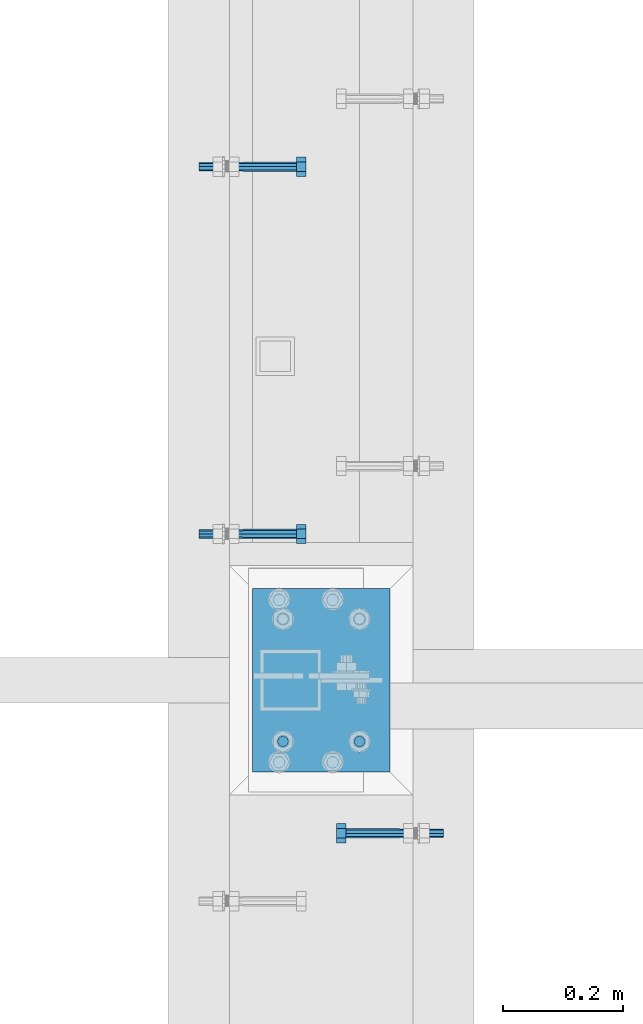
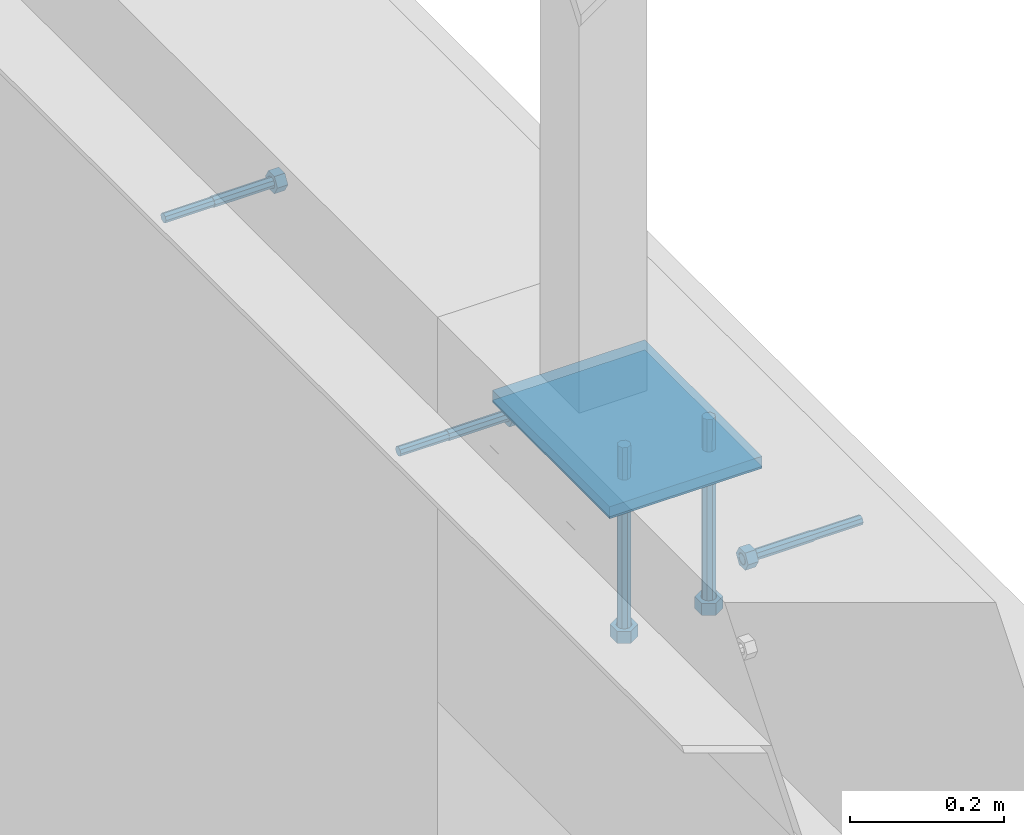
# One storey, part 390 of 975: 7 beams.
"""IFC2X3 building model written with IfcOpenShell, lengths in millimetres."""

from ifc_helpers import new_model, si_unit, frame, origin_with_axes, place, context, subcontext, project, spatial, faceted_brep, material, type_object, element, save


model = new_model("IFC2X3")

# Units and contexts
model_context = context("Model", 3, precision=1e-05, world=origin_with_axes())
body_context = subcontext(model_context, "Body", "Model", "MODEL_VIEW")
ifc_project = project(units=[si_unit("LENGTHUNIT", "METRE", prefix="MILLI"), si_unit("AREAUNIT", "SQUARE_METRE"), si_unit("VOLUMEUNIT", "CUBIC_METRE"), si_unit("MASSUNIT", "GRAM", prefix="KILO"), si_unit("TIMEUNIT", "SECOND"), si_unit("PLANEANGLEUNIT", "RADIAN"), si_unit("SOLIDANGLEUNIT", "STERADIAN"), si_unit("THERMODYNAMICTEMPERATUREUNIT", "DEGREE_CELSIUS"), si_unit("LUMINOUSINTENSITYUNIT", "LUMEN")], contexts=[model_context])

# Site, building, storey
site_placement = place(None, origin_with_axes())
site = spatial("IfcSite", under=ifc_project, at=site_placement, CompositionType="ELEMENT")
building_placement = place(site_placement, origin_with_axes())
building = spatial("IfcBuilding", under=site, at=building_placement, Name="Undefined", CompositionType="ELEMENT")
storey_placement = place(building_placement, origin_with_axes())
storey = spatial("IfcBuildingStorey", under=building, at=storey_placement, Name="Undefined", CompositionType="ELEMENT", Elevation=0.0)

# Beams
ifc_material_1 = material(Name="STEEL/F1554-36")
beam_type_1 = type_object("IfcBeamType", PredefinedType="NOTDEFINED")
beam_1_placement = place(storey_placement, frame((2038.34998493445, 7967.66249985328, 3835.4), z_axis=(0.0, 0.0, -1.0), x_axis=(1.0, 0.0, 0.0)))
element("IfcBeam", 1, at=beam_1_placement, inside=storey, type_object=beam_type_1, material=ifc_material_1, Name="HEADED_ANCHOR_BOLT", context=body_context, shape_type="Brep", body=[
    faceted_brep([(88.9000000184824, 7.94000001861696, -13.7499999799138), (88.8999999527368, 15.8800000758411, 2.00943759409711e-08), (104.774999952569, 15.8800001213949, 6.97191353538074e-08), (104.775000018315, 7.94000006417082, -13.7499999302891), (88.900000064019, -7.94000009583215, -13.7499999799147), (104.775000063852, -7.9400000502792, -13.74999993029), (88.9000000438027, -15.880000153059, 2.00925569515675e-08), (104.775000043643, -15.8800001075042, 6.9716406869702e-08), (88.8999999780608, -7.94000009583488, 13.7500000200998), (104.774999977893, -7.94000005028101, 13.7500000697237), (88.8999999325279, 7.94000001861514, 13.7500000201007), (104.774999932361, 7.940000064169, 13.7500000697246), (88.9000000119959, 3.78780480527439, -7.86545778426807), (88.8999999957159, 6.82538844544797, -5.4430656647246), (88.8999999799416, 8.51112018845743, -1.94260763148395), (88.8999999677944, 8.51112018845652, 1.94260767167179), (88.8999999616899, 6.82538844544615, 5.44306570491244), (88.8999999628249, 3.78780480527257, 7.86545782445592), (88.8999999709849, -3.86089595849626e-08, 8.72999956233434), (88.8999999845473, -3.7878048824914, 7.8654578244541), (88.9000000008309, -6.82538852266407, 5.44306570491153), (88.9000000166052, -8.51112026567444, 1.94260767166998), (88.9000000287488, -8.51112026567353, -1.94260763148577), (88.9000000348606, -6.82538852266407, -5.44306566472642), (88.9000000337182, -3.78780488248958, -7.86545778426898), (88.9000000255583, -3.86080500902608e-08, -8.72999952214832), (104.775000025395, 6.94581103743985e-09, -8.72999947252447), (104.775000011829, 3.78780485082825, -7.86545773464422), (104.774999995549, 6.82538849100092, -5.44306561510075), (104.774999979774, 8.51112023401038, -1.9426075818601), (104.774999967627, 8.51112023401038, 1.94260772129564), (104.774999961523, 6.82538849100092, 5.44306575453629), (104.774999962658, 3.78780485082643, 7.86545787407977), (104.774999970818, 6.94399204803631e-09, 8.7299996119591), (104.77499998438, -3.78780483693754, 7.86545787407886), (104.775000000664, -6.82538847711112, 5.44306575453538), (104.775000016438, -8.51112022012057, 1.94260772129473), (104.775000028581, -8.51112022012057, -1.94260758186101), (104.775000034693, -6.82538847711021, -5.44306561510166), (104.775000033551, -3.78780483693663, -7.86545773464422), (-2.99107341561466e-07, -5.61266007567065, 5.61266007566792), (-4.22995071858168e-07, -7.93750000000728, 0.0), (104.774999998088, -7.93749999999, -4.45652403868735e-11), (104.774999998088, -5.61266007565791, 5.61266007562426), (-1.09139364212751e-11, 1.81898940354586e-12, 7.9375), (104.774999998095, 1.18234311230481e-11, 7.93749999995816), (2.99089151667431e-07, 5.61266007567428, 5.61266007566792), (104.774999998102, 5.61266007568065, 5.61266007562517), (4.22980519942939e-07, 7.93750000001091, 0.0), (104.77499999811, 7.93750000001364, -4.36557456851006e-11), (2.99089151667431e-07, 5.61266007567428, -5.61266007566792), (104.774999998102, 5.61266007568156, -5.61266007571339), (-1.09139364212751e-11, 1.81898940354586e-12, -7.9375), (104.774999998099, 1.2732925824821e-11, -7.93750000004547), (-73.0249999592124, 5.05157065939329, -5.0515715445581), (-73.0249999269472, -1.85405951924622e-07, -7.14400069976364), (-73.0249999328516, -5.0515710302052, -5.05157154455992), (-73.0249999734697, -7.14400018541073, -6.9975976657588e-07), (-73.0250000250016, -5.05157103020611, 5.05157014504039), (-73.0250000572705, -1.85406861419324e-07, 7.1439993002441), (-73.0250000513661, 5.05157065939238, 5.05157014503948), (-73.025000010748, 7.14399981459792, -6.99758857081179e-07), (0.00625003290042514, 5.05157085007795, -5.05157087849238), (0.00625006516929716, 5.27870724909008e-09, -7.1440000336961), (0.00625005926485755, -5.05157083952145, -5.05157087849329), (0.00625001864682417, -7.14399999472516, -3.36940502165817e-08), (0.00624996711121639, -5.05157083952145, 5.05157081110519), (0.00624993484598235, 5.2777977543883e-09, 7.14399996631164), (0.00624994074678398, 5.05157085007704, 5.05157081110701), (0.00624998136845534, 7.14400000528167, -3.36922312271781e-08), (-2.99107341561466e-07, -5.61266007567065, -5.61266007566792), (104.774999998092, -5.612660075657, -5.6126600757143)], [[[0, 1, 2, 3]], [[4, 0, 3, 5]], [[6, 4, 5, 7]], [[8, 6, 7, 9]], [[10, 8, 9, 11]], [[0, 4, 6, 8, 10, 1], [12, 13, 14, 15, 16, 17, 18, 19, 20, 21, 22, 23, 24, 25]], [[12, 25, 26, 27]], [[13, 12, 27, 28]], [[14, 13, 28, 29]], [[15, 14, 29, 30]], [[16, 15, 30, 31]], [[17, 16, 31, 32]], [[18, 17, 32, 33]], [[19, 18, 33, 34]], [[20, 19, 34, 35]], [[21, 20, 35, 36]], [[22, 21, 36, 37]], [[23, 22, 37, 38]], [[24, 23, 38, 39]], [[25, 24, 39, 26]], [[9, 7, 5, 3, 2, 11], [38, 37, 36, 35, 34, 33, 32, 31, 30, 29, 28, 27, 26, 39]], [[1, 10, 11, 2]], [[40, 41, 42, 43]], [[44, 40, 43, 45]], [[46, 44, 45, 47]], [[48, 46, 47, 49]], [[50, 48, 49, 51]], [[52, 50, 51, 53]], [[54, 55, 56, 57, 58, 59, 60, 61]], [[55, 54, 62, 63]], [[56, 55, 63, 64]], [[57, 56, 64, 65]], [[58, 57, 65, 66]], [[59, 58, 66, 67]], [[60, 59, 67, 68]], [[61, 60, 68, 69]], [[54, 61, 69, 62]], [[40, 44, 46, 48, 50, 52, 70, 41], [68, 67, 66, 65, 64, 63, 62, 69]], [[41, 70, 71, 42]], [[53, 51, 49, 47, 45, 43, 42, 71]], [[70, 52, 53, 71]]]),
])
beam_2_placement = place(storey_placement, frame((2038.34998066725, 7358.06240219702, 3835.4), z_axis=(0.0, 0.0, -1.0), x_axis=(1.0, 0.0, 0.0)))
element("IfcBeam", 2, at=beam_2_placement, inside=storey, type_object=beam_type_1, material=ifc_material_1, Name="HEADED_ANCHOR_BOLT", context=body_context, shape_type="Brep", body=[
    faceted_brep([(88.9000000184824, 7.94000001861696, -13.7499999799138), (88.8999999527368, 15.8800000758411, 2.00943759409711e-08), (104.774999952569, 15.8800001213949, 6.97191353538074e-08), (104.775000018315, 7.94000006417082, -13.7499999302891), (88.900000064019, -7.94000009583215, -13.7499999799147), (104.775000063852, -7.9400000502792, -13.74999993029), (88.9000000438027, -15.880000153059, 2.00925569515675e-08), (104.775000043643, -15.8800001075042, 6.9716406869702e-08), (88.8999999780608, -7.94000009583488, 13.7500000200998), (104.774999977893, -7.94000005028101, 13.7500000697237), (88.8999999325279, 7.94000001861514, 13.7500000201007), (104.774999932361, 7.940000064169, 13.7500000697246), (88.9000000119959, 3.78780480527439, -7.86545778426807), (88.8999999957159, 6.82538844544797, -5.4430656647246), (88.8999999799416, 8.51112018845743, -1.94260763148395), (88.8999999677944, 8.51112018845652, 1.94260767167179), (88.8999999616899, 6.82538844544615, 5.44306570491244), (88.8999999628249, 3.78780480527257, 7.86545782445592), (88.8999999709849, -3.86089595849626e-08, 8.72999956233434), (88.8999999845473, -3.7878048824914, 7.8654578244541), (88.9000000008309, -6.82538852266407, 5.44306570491153), (88.9000000166052, -8.51112026567444, 1.94260767166998), (88.9000000287488, -8.51112026567353, -1.94260763148577), (88.9000000348606, -6.82538852266407, -5.44306566472642), (88.9000000337182, -3.78780488248958, -7.86545778426898), (88.9000000255583, -3.86080500902608e-08, -8.72999952214832), (104.775000025395, 6.94581103743985e-09, -8.72999947252447), (104.775000011829, 3.78780485082825, -7.86545773464422), (104.774999995549, 6.82538849100092, -5.44306561510075), (104.774999979774, 8.51112023401038, -1.9426075818601), (104.774999967627, 8.51112023401038, 1.94260772129564), (104.774999961523, 6.82538849100092, 5.44306575453629), (104.774999962658, 3.78780485082643, 7.86545787407977), (104.774999970818, 6.94399204803631e-09, 8.7299996119591), (104.77499998438, -3.78780483693754, 7.86545787407886), (104.775000000664, -6.82538847711112, 5.44306575453538), (104.775000016438, -8.51112022012057, 1.94260772129473), (104.775000028581, -8.51112022012057, -1.94260758186101), (104.775000034693, -6.82538847711021, -5.44306561510166), (104.775000033551, -3.78780483693663, -7.86545773464422), (-2.99107341561466e-07, -5.61266007567065, 5.61266007566792), (-4.22995071858168e-07, -7.93750000000728, 0.0), (104.774999998088, -7.93749999999, -4.45652403868735e-11), (104.774999998088, -5.61266007565791, 5.61266007562426), (-1.09139364212751e-11, 1.81898940354586e-12, 7.9375), (104.774999998095, 1.18234311230481e-11, 7.93749999995816), (2.99089151667431e-07, 5.61266007567428, 5.61266007566792), (104.774999998102, 5.61266007568065, 5.61266007562517), (4.22980519942939e-07, 7.93750000001091, 0.0), (104.77499999811, 7.93750000001364, -4.36557456851006e-11), (2.99089151667431e-07, 5.61266007567428, -5.61266007566792), (104.774999998102, 5.61266007568156, -5.61266007571339), (-1.09139364212751e-11, 1.81898940354586e-12, -7.9375), (104.774999998099, 1.2732925824821e-11, -7.93750000004547), (-73.0249999592124, 5.05157065939329, -5.0515715445581), (-73.0249999269472, -1.85405951924622e-07, -7.14400069976364), (-73.0249999328516, -5.0515710302052, -5.05157154455992), (-73.0249999734697, -7.14400018541073, -6.9975976657588e-07), (-73.0250000250016, -5.05157103020611, 5.05157014504039), (-73.0250000572705, -1.85406861419324e-07, 7.1439993002441), (-73.0250000513661, 5.05157065939238, 5.05157014503948), (-73.025000010748, 7.14399981459792, -6.99758857081179e-07), (0.00625003290042514, 5.05157085007795, -5.05157087849238), (0.00625006516929716, 5.27870724909008e-09, -7.1440000336961), (0.00625005926485755, -5.05157083952145, -5.05157087849329), (0.00625001864682417, -7.14399999472516, -3.36940502165817e-08), (0.00624996711121639, -5.05157083952145, 5.05157081110519), (0.00624993484598235, 5.2777977543883e-09, 7.14399996631164), (0.00624994074678398, 5.05157085007704, 5.05157081110701), (0.00624998136845534, 7.14400000528167, -3.36922312271781e-08), (-2.99107341561466e-07, -5.61266007567065, -5.61266007566792), (104.774999998092, -5.612660075657, -5.6126600757143)], [[[0, 1, 2, 3]], [[4, 0, 3, 5]], [[6, 4, 5, 7]], [[8, 6, 7, 9]], [[10, 8, 9, 11]], [[0, 4, 6, 8, 10, 1], [12, 13, 14, 15, 16, 17, 18, 19, 20, 21, 22, 23, 24, 25]], [[12, 25, 26, 27]], [[13, 12, 27, 28]], [[14, 13, 28, 29]], [[15, 14, 29, 30]], [[16, 15, 30, 31]], [[17, 16, 31, 32]], [[18, 17, 32, 33]], [[19, 18, 33, 34]], [[20, 19, 34, 35]], [[21, 20, 35, 36]], [[22, 21, 36, 37]], [[23, 22, 37, 38]], [[24, 23, 38, 39]], [[25, 24, 39, 26]], [[9, 7, 5, 3, 2, 11], [38, 37, 36, 35, 34, 33, 32, 31, 30, 29, 28, 27, 26, 39]], [[1, 10, 11, 2]], [[40, 41, 42, 43]], [[44, 40, 43, 45]], [[46, 44, 45, 47]], [[48, 46, 47, 49]], [[50, 48, 49, 51]], [[52, 50, 51, 53]], [[54, 55, 56, 57, 58, 59, 60, 61]], [[55, 54, 62, 63]], [[56, 55, 63, 64]], [[57, 56, 64, 65]], [[58, 57, 65, 66]], [[59, 58, 66, 67]], [[60, 59, 67, 68]], [[61, 60, 68, 69]], [[54, 61, 69, 62]], [[40, 44, 46, 48, 50, 52, 70, 41], [68, 67, 66, 65, 64, 63, 62, 69]], [[41, 70, 71, 42]], [[53, 51, 49, 47, 45, 43, 42, 71]], [[70, 52, 53, 71]]]),
])
beam_3_placement = place(storey_placement, frame((2298.70006496676, 6861.17497611239, 3886.2), z_axis=(0.0, 0.0, 1.0), x_axis=(-0.999999999999998, 6.90000001668524e-08, 0.0)))
element("IfcBeam", 3, at=beam_3_placement, inside=storey, type_object=beam_type_1, material=ifc_material_1, Name="HEADED_ANCHOR_BOLT", context=body_context, shape_type="Brep", body=[
    faceted_brep([(88.9000000184824, 7.94000001861696, -13.7499999799138), (88.8999999527368, 15.8800000758411, 2.00943759409711e-08), (104.774999952569, 15.8800001213949, 6.97191353538074e-08), (104.775000018315, 7.94000006417082, -13.7499999302891), (88.900000064019, -7.94000009583215, -13.7499999799147), (104.775000063852, -7.9400000502792, -13.74999993029), (88.9000000438027, -15.880000153059, 2.00925569515675e-08), (104.775000043643, -15.8800001075042, 6.9716406869702e-08), (88.8999999780608, -7.94000009583488, 13.7500000200998), (104.774999977893, -7.94000005028101, 13.7500000697237), (88.8999999325279, 7.94000001861514, 13.7500000201007), (104.774999932361, 7.940000064169, 13.7500000697246), (88.9000000119959, 3.78780480527439, -7.86545778426807), (88.8999999957159, 6.82538844544797, -5.4430656647246), (88.8999999799416, 8.51112018845743, -1.94260763148395), (88.8999999677944, 8.51112018845652, 1.94260767167179), (88.8999999616899, 6.82538844544615, 5.44306570491244), (88.8999999628249, 3.78780480527257, 7.86545782445592), (88.8999999709849, -3.86089595849626e-08, 8.72999956233434), (88.8999999845473, -3.7878048824914, 7.8654578244541), (88.9000000008309, -6.82538852266407, 5.44306570491153), (88.9000000166052, -8.51112026567444, 1.94260767166998), (88.9000000287488, -8.51112026567353, -1.94260763148577), (88.9000000348606, -6.82538852266407, -5.44306566472642), (88.9000000337182, -3.78780488248958, -7.86545778426898), (88.9000000255583, -3.86080500902608e-08, -8.72999952214832), (104.775000025395, 6.94581103743985e-09, -8.72999947252447), (104.775000011829, 3.78780485082825, -7.86545773464422), (104.774999995549, 6.82538849100092, -5.44306561510075), (104.774999979774, 8.51112023401038, -1.9426075818601), (104.774999967627, 8.51112023401038, 1.94260772129564), (104.774999961523, 6.82538849100092, 5.44306575453629), (104.774999962658, 3.78780485082643, 7.86545787407977), (104.774999970818, 6.94399204803631e-09, 8.7299996119591), (104.77499998438, -3.78780483693754, 7.86545787407886), (104.775000000664, -6.82538847711112, 5.44306575453538), (104.775000016438, -8.51112022012057, 1.94260772129473), (104.775000028581, -8.51112022012057, -1.94260758186101), (104.775000034693, -6.82538847711021, -5.44306561510166), (104.775000033551, -3.78780483693663, -7.86545773464422), (-2.99107341561466e-07, -5.61266007567065, 5.61266007566792), (-4.22995071858168e-07, -7.93750000000728, 0.0), (104.774999998088, -7.93749999999, -4.45652403868735e-11), (104.774999998088, -5.61266007565791, 5.61266007562426), (-1.09139364212751e-11, 1.81898940354586e-12, 7.9375), (104.774999998095, 1.18234311230481e-11, 7.93749999995816), (2.99089151667431e-07, 5.61266007567428, 5.61266007566792), (104.774999998102, 5.61266007568065, 5.61266007562517), (4.22980519942939e-07, 7.93750000001091, 0.0), (104.77499999811, 7.93750000001364, -4.36557456851006e-11), (2.99089151667431e-07, 5.61266007567428, -5.61266007566792), (104.774999998102, 5.61266007568156, -5.61266007571339), (-1.09139364212751e-11, 1.81898940354586e-12, -7.9375), (104.774999998099, 1.2732925824821e-11, -7.93750000004547), (-73.0249999592124, 5.05157065939329, -5.0515715445581), (-73.0249999269472, -1.85405951924622e-07, -7.14400069976364), (-73.0249999328516, -5.0515710302052, -5.05157154455992), (-73.0249999734697, -7.14400018541073, -6.9975976657588e-07), (-73.0250000250016, -5.05157103020611, 5.05157014504039), (-73.0250000572705, -1.85406861419324e-07, 7.1439993002441), (-73.0250000513661, 5.05157065939238, 5.05157014503948), (-73.025000010748, 7.14399981459792, -6.99758857081179e-07), (0.00625003290042514, 5.05157085007795, -5.05157087849238), (0.00625006516929716, 5.27870724909008e-09, -7.1440000336961), (0.00625005926485755, -5.05157083952145, -5.05157087849329), (0.00625001864682417, -7.14399999472516, -3.36940502165817e-08), (0.00624996711121639, -5.05157083952145, 5.05157081110519), (0.00624993484598235, 5.2777977543883e-09, 7.14399996631164), (0.00624994074678398, 5.05157085007704, 5.05157081110701), (0.00624998136845534, 7.14400000528167, -3.36922312271781e-08), (-2.99107341561466e-07, -5.61266007567065, -5.61266007566792), (104.774999998092, -5.612660075657, -5.6126600757143)], [[[0, 1, 2, 3]], [[4, 0, 3, 5]], [[6, 4, 5, 7]], [[8, 6, 7, 9]], [[10, 8, 9, 11]], [[0, 4, 6, 8, 10, 1], [12, 13, 14, 15, 16, 17, 18, 19, 20, 21, 22, 23, 24, 25]], [[12, 25, 26, 27]], [[13, 12, 27, 28]], [[14, 13, 28, 29]], [[15, 14, 29, 30]], [[16, 15, 30, 31]], [[17, 16, 31, 32]], [[18, 17, 32, 33]], [[19, 18, 33, 34]], [[20, 19, 34, 35]], [[21, 20, 35, 36]], [[22, 21, 36, 37]], [[23, 22, 37, 38]], [[24, 23, 38, 39]], [[25, 24, 39, 26]], [[9, 7, 5, 3, 2, 11], [38, 37, 36, 35, 34, 33, 32, 31, 30, 29, 28, 27, 26, 39]], [[1, 10, 11, 2]], [[40, 41, 42, 43]], [[44, 40, 43, 45]], [[46, 44, 45, 47]], [[48, 46, 47, 49]], [[50, 48, 49, 51]], [[52, 50, 51, 53]], [[54, 55, 56, 57, 58, 59, 60, 61]], [[55, 54, 62, 63]], [[56, 55, 63, 64]], [[57, 56, 64, 65]], [[58, 57, 65, 66]], [[59, 58, 66, 67]], [[60, 59, 67, 68]], [[61, 60, 68, 69]], [[54, 61, 69, 62]], [[40, 44, 46, 48, 50, 52, 70, 41], [68, 67, 66, 65, 64, 63, 62, 69]], [[41, 70, 71, 42]], [[53, 51, 49, 47, 45, 43, 42, 71]], [[70, 52, 53, 71]]]),
])
beam_type_2 = type_object("IfcBeamType", PredefinedType="NOTDEFINED")
beam_4_placement = place(storey_placement, frame((2105.025, 7013.57499984381, 3917.95), z_axis=(1.0, 0.0, 0.0), x_axis=(0.0, 0.0, -1.0)))
element("IfcBeam", 4, at=beam_4_placement, inside=storey, type_object=beam_type_2, material=ifc_material_1, Name="HEADED_BOLT", context=body_context, shape_type="Brep", body=[
    faceted_brep([(196.84375, -9.12999965559902, 15.8099993757314), (196.84375, -18.2599997700399, -1.0438852768857e-06), (215.893749999999, -18.2599997700399, -1.0438852768857e-06), (215.893749999999, -9.12999965559902, 15.8099993757314), (196.84375, 9.13000057328281, 15.8099993757314), (215.893749999999, 9.13000057328281, 15.8099993757314), (196.84375, 18.2600006877237, -1.0438852768857e-06), (215.893749999999, 18.2600006877237, -1.0438852768857e-06), (196.84375, 9.13000057328281, -15.810001463502), (215.893749999999, 9.13000057328281, -15.810001463502), (196.84375, -9.12999965559902, -15.810001463502), (215.893749999999, -9.12999965559902, -15.810001463502), (196.84375, -4.47767959644079, 9.2979973979138), (196.84375, -8.06850020163256, 6.43441352102286), (196.84375, -10.0612552973498, 2.29641492663589), (196.84375, -10.0612552973498, -2.29641701440644), (196.84375, -8.06850020163256, -6.43441560879344), (196.84375, -4.47767959644079, -9.29799948568439), (196.84375, 4.58841896033846e-07, -10.3200007387095), (196.84375, 4.47768051412459, -9.29799948568436), (196.84375, 8.06850111931635, -6.43441560879342), (196.84375, 10.0612562150336, -2.29641701440644), (196.84375, 10.0612562150336, 2.29641492663589), (196.84375, 8.06850111931635, 6.43441352102289), (196.84375, 4.47768051412459, 9.29799739791383), (196.84375, 4.58841896033846e-07, 10.3199986509389), (215.893749999999, 4.58841896033846e-07, 10.3199986509389), (215.893749999999, -4.47767959644079, 9.2979973979138), (215.893749999999, -8.06850020163256, 6.43441352102286), (215.893749999999, -10.0612552973498, 2.29641492663589), (215.893749999999, -10.0612552973498, -2.29641701440644), (215.893749999999, -8.06850020163256, -6.43441560879344), (215.893749999999, -4.47767959644079, -9.29799948568439), (215.893749999999, 4.58841896033846e-07, -10.3200007387095), (215.893749999999, 4.47768051412459, -9.29799948568436), (215.893749999999, 8.06850111931635, -6.43441560879342), (215.893749999999, 10.0612562150336, -2.29641701440644), (215.893749999999, 10.0612562150336, 2.29641492663589), (215.893749999999, 8.06850111931635, 6.43441352102289), (215.893749999999, 4.47768051412459, 9.29799739791383), (0.0, -6.73519209080223, 6.73519209080186), (0.0, -9.52499999999964, 0.0), (215.900000000001, -9.52499999999964, 0.0), (215.900000000001, -6.73519209080223, 6.73519209080186), (-9.87109982941227e-13, -1.20792265079217e-13, 9.52499961853027), (215.900000000001, 0.0, 9.52500000000001), (0.0, 6.73519209080223, 6.73519209080186), (215.900000000001, 6.73519209080223, 6.73519209080186), (0.0, 9.52499999999964, 0.0), (215.900000000001, 9.52499999999964, 0.0), (0.0, 6.73519209080223, -6.73519209080186), (215.900000000001, 6.73519209080223, -6.73519209080186), (2.95075507493764e-12, -1.20792265079217e-13, -9.52499961853027), (215.900000000001, 0.0, -9.52500000000001), (-88.9444446471748, -6.3639605718372, 6.39952908988423), (-88.9433906823501, 4.58841896033846e-07, 9.03556784850662), (-88.9444446471748, 6.36396148952099, 6.39952908988423), (-88.9469891433491, 9.0000004588419, 0.0355685678769078), (-88.9495336395235, 6.36396148952099, -6.32839195413041), (-88.9505876043481, 4.58841896033846e-07, -8.9644307127528), (-88.9495336395235, -6.3639605718372, -6.32839195413041), (-88.9469891433491, -8.9999995411581, 0.0355685678769078), (0.0124298302243915, 6.36396148952099, -6.36396152997716), (0.0113758653997138, 4.58841896033846e-07, -9.00000028859955), (0.0124298302243915, -6.3639605718372, -6.36396152997716), (0.0149743263987148, -8.9999995411581, -1.00796984270346e-06), (0.0175188225730381, -6.3639605718372, 6.36395951403748), (0.0185727873977157, 4.58841896033846e-07, 8.99999827265987), (0.0175188225730381, 6.36396148952099, 6.36395951403748), (0.0149743263987148, 9.0000004588419, -1.00796984270346e-06), (0.0, -6.73519209080223, -6.73519209080186), (215.900000000001, -6.73519209080223, -6.73519209080186)], [[[0, 1, 2, 3]], [[4, 0, 3, 5]], [[6, 4, 5, 7]], [[8, 6, 7, 9]], [[10, 8, 9, 11]], [[0, 4, 6, 8, 10, 1], [12, 13, 14, 15, 16, 17, 18, 19, 20, 21, 22, 23, 24, 25]], [[12, 25, 26, 27]], [[13, 12, 27, 28]], [[14, 13, 28, 29]], [[15, 14, 29, 30]], [[16, 15, 30, 31]], [[17, 16, 31, 32]], [[18, 17, 32, 33]], [[19, 18, 33, 34]], [[20, 19, 34, 35]], [[21, 20, 35, 36]], [[22, 21, 36, 37]], [[23, 22, 37, 38]], [[24, 23, 38, 39]], [[25, 24, 39, 26]], [[9, 7, 5, 3, 2, 11], [38, 37, 36, 35, 34, 33, 32, 31, 30, 29, 28, 27, 26, 39]], [[1, 10, 11, 2]], [[40, 41, 42, 43]], [[44, 40, 43, 45]], [[46, 44, 45, 47]], [[48, 46, 47, 49]], [[50, 48, 49, 51]], [[52, 50, 51, 53]], [[54, 55, 56, 57, 58, 59, 60, 61]], [[59, 58, 62, 63]], [[60, 59, 63, 64]], [[61, 60, 64, 65]], [[54, 61, 65, 66]], [[55, 54, 66, 67]], [[56, 55, 67, 68]], [[57, 56, 68, 69]], [[58, 57, 69, 62]], [[40, 44, 46, 48, 50, 52, 70, 41], [68, 67, 66, 65, 64, 63, 62, 69]], [[41, 70, 71, 42]], [[53, 51, 49, 47, 45, 43, 42, 71]], [[70, 52, 53, 71]]]),
])
beam_5_placement = place(storey_placement, frame((2232.0249962741, 7013.57499984381, 3917.95), z_axis=(1.0, 0.0, 0.0), x_axis=(0.0, 0.0, -1.0)))
element("IfcBeam", 5, at=beam_5_placement, inside=storey, type_object=beam_type_2, material=ifc_material_1, Name="HEADED_BOLT", context=body_context, shape_type="Brep", body=[
    faceted_brep([(196.84375, -9.12999965559902, 15.8099993757314), (196.84375, -18.2599997700399, -1.0438852768857e-06), (215.893749999999, -18.2599997700399, -1.0438852768857e-06), (215.893749999999, -9.12999965559902, 15.8099993757314), (196.84375, 9.13000057328281, 15.8099993757314), (215.893749999999, 9.13000057328281, 15.8099993757314), (196.84375, 18.2600006877237, -1.0438852768857e-06), (215.893749999999, 18.2600006877237, -1.0438852768857e-06), (196.84375, 9.13000057328281, -15.810001463502), (215.893749999999, 9.13000057328281, -15.810001463502), (196.84375, -9.12999965559902, -15.810001463502), (215.893749999999, -9.12999965559902, -15.810001463502), (196.84375, -4.47767959644079, 9.2979973979138), (196.84375, -8.06850020163256, 6.43441352102286), (196.84375, -10.0612552973498, 2.29641492663589), (196.84375, -10.0612552973498, -2.29641701440644), (196.84375, -8.06850020163256, -6.43441560879344), (196.84375, -4.47767959644079, -9.29799948568439), (196.84375, 4.58841896033846e-07, -10.3200007387095), (196.84375, 4.47768051412459, -9.29799948568436), (196.84375, 8.06850111931635, -6.43441560879342), (196.84375, 10.0612562150336, -2.29641701440644), (196.84375, 10.0612562150336, 2.29641492663589), (196.84375, 8.06850111931635, 6.43441352102289), (196.84375, 4.47768051412459, 9.29799739791383), (196.84375, 4.58841896033846e-07, 10.3199986509389), (215.893749999999, 4.58841896033846e-07, 10.3199986509389), (215.893749999999, -4.47767959644079, 9.2979973979138), (215.893749999999, -8.06850020163256, 6.43441352102286), (215.893749999999, -10.0612552973498, 2.29641492663589), (215.893749999999, -10.0612552973498, -2.29641701440644), (215.893749999999, -8.06850020163256, -6.43441560879344), (215.893749999999, -4.47767959644079, -9.29799948568439), (215.893749999999, 4.58841896033846e-07, -10.3200007387095), (215.893749999999, 4.47768051412459, -9.29799948568436), (215.893749999999, 8.06850111931635, -6.43441560879342), (215.893749999999, 10.0612562150336, -2.29641701440644), (215.893749999999, 10.0612562150336, 2.29641492663589), (215.893749999999, 8.06850111931635, 6.43441352102289), (215.893749999999, 4.47768051412459, 9.29799739791383), (0.0, -6.73519209080223, 6.73519209080186), (0.0, -9.52499999999964, 0.0), (215.900000000001, -9.52499999999964, 0.0), (215.900000000001, -6.73519209080223, 6.73519209080186), (-9.87109982941227e-13, -1.20792265079217e-13, 9.52499961853027), (215.900000000001, 0.0, 9.52500000000001), (0.0, 6.73519209080223, 6.73519209080186), (215.900000000001, 6.73519209080223, 6.73519209080186), (0.0, 9.52499999999964, 0.0), (215.900000000001, 9.52499999999964, 0.0), (0.0, 6.73519209080223, -6.73519209080186), (215.900000000001, 6.73519209080223, -6.73519209080186), (2.95075507493764e-12, -1.20792265079217e-13, -9.52499961853027), (215.900000000001, 0.0, -9.52500000000001), (-88.9444446471748, -6.3639605718372, 6.39952908988423), (-88.9433906823501, 4.58841896033846e-07, 9.03556784850662), (-88.9444446471748, 6.36396148952099, 6.39952908988423), (-88.9469891433491, 9.0000004588419, 0.0355685678769078), (-88.9495336395235, 6.36396148952099, -6.32839195413041), (-88.9505876043481, 4.58841896033846e-07, -8.9644307127528), (-88.9495336395235, -6.3639605718372, -6.32839195413041), (-88.9469891433491, -8.9999995411581, 0.0355685678769078), (0.0124298302243915, 6.36396148952099, -6.36396152997716), (0.0113758653997138, 4.58841896033846e-07, -9.00000028859955), (0.0124298302243915, -6.3639605718372, -6.36396152997716), (0.0149743263987148, -8.9999995411581, -1.00796984270346e-06), (0.0175188225730381, -6.3639605718372, 6.36395951403748), (0.0185727873977157, 4.58841896033846e-07, 8.99999827265987), (0.0175188225730381, 6.36396148952099, 6.36395951403748), (0.0149743263987148, 9.0000004588419, -1.00796984270346e-06), (0.0, -6.73519209080223, -6.73519209080186), (215.900000000001, -6.73519209080223, -6.73519209080186)], [[[0, 1, 2, 3]], [[4, 0, 3, 5]], [[6, 4, 5, 7]], [[8, 6, 7, 9]], [[10, 8, 9, 11]], [[0, 4, 6, 8, 10, 1], [12, 13, 14, 15, 16, 17, 18, 19, 20, 21, 22, 23, 24, 25]], [[12, 25, 26, 27]], [[13, 12, 27, 28]], [[14, 13, 28, 29]], [[15, 14, 29, 30]], [[16, 15, 30, 31]], [[17, 16, 31, 32]], [[18, 17, 32, 33]], [[19, 18, 33, 34]], [[20, 19, 34, 35]], [[21, 20, 35, 36]], [[22, 21, 36, 37]], [[23, 22, 37, 38]], [[24, 23, 38, 39]], [[25, 24, 39, 26]], [[9, 7, 5, 3, 2, 11], [38, 37, 36, 35, 34, 33, 32, 31, 30, 29, 28, 27, 26, 39]], [[1, 10, 11, 2]], [[40, 41, 42, 43]], [[44, 40, 43, 45]], [[46, 44, 45, 47]], [[48, 46, 47, 49]], [[50, 48, 49, 51]], [[52, 50, 51, 53]], [[54, 55, 56, 57, 58, 59, 60, 61]], [[59, 58, 62, 63]], [[60, 59, 63, 64]], [[61, 60, 64, 65]], [[54, 61, 65, 66]], [[55, 54, 66, 67]], [[56, 55, 67, 68]], [[57, 56, 68, 69]], [[58, 57, 69, 62]], [[40, 44, 46, 48, 50, 52, 70, 41], [68, 67, 66, 65, 64, 63, 62, 69]], [[41, 70, 71, 42]], [[53, 51, 49, 47, 45, 43, 42, 71]], [[70, 52, 53, 71]]]),
])
ifc_material_2 = material(Name="STEEL/A36")
beam_type_3 = type_object("IfcBeamType", PredefinedType="NOTDEFINED")
beam_6_placement = place(storey_placement, frame((2054.22499847412, 7115.175, 3946.525), z_axis=(0.0, 1.0, 0.0), x_axis=(1.0, 0.0, 0.0)))
element("IfcBeam", 6, at=beam_6_placement, inside=storey, type_object=beam_type_3, material=ifc_material_2, Name="PLATE", context=body_context, shape_type="Brep", body=[
    faceted_brep([(0.0, 9.52499999999964, -152.4), (0.0, 9.52499999999964, 152.4), (228.600003051761, 9.52500000000009, 152.4), (228.600003051761, 9.52500000000009, -152.4), (0.0, -9.52499999999964, 152.4), (228.600003051761, -9.52500000000009, 152.4), (0.0, -9.52499999999964, -152.4), (228.600003051761, -9.52500000000009, -152.4)], [[[0, 1, 2, 3]], [[1, 4, 5, 2]], [[4, 6, 7, 5]], [[6, 0, 3, 7]], [[5, 7, 3, 2]], [[6, 4, 1, 0]]]),
])
beam_type_4 = type_object("IfcBeamType", PredefinedType="NOTDEFINED")
beam_7_placement = place(storey_placement, frame((2054.22499847412, 7115.175, 3938.5875), z_axis=(0.0, 1.0, 0.0), x_axis=(1.0, 0.0, 0.0)))
element("IfcBeam", 7, at=beam_7_placement, inside=storey, type_object=beam_type_4, material=ifc_material_2, Name="TEMPLATE", context=body_context, shape_type="Brep", body=[
    faceted_brep([(0.0, 1.58750000000009, -152.4), (0.0, 1.58750000000009, 152.4), (228.600003051761, 1.58750000000009, 152.4), (228.600003051761, 1.58750000000009, -152.4), (0.0, -1.58750000000009, 152.4), (228.600003051761, -1.58750000000009, 152.4), (0.0, -1.58750000000009, -152.4), (228.600003051761, -1.58750000000009, -152.4)], [[[0, 1, 2, 3]], [[1, 4, 5, 2]], [[4, 6, 7, 5]], [[6, 0, 3, 7]], [[5, 7, 3, 2]], [[6, 4, 1, 0]]]),
])

save(model, "model.ifc")
